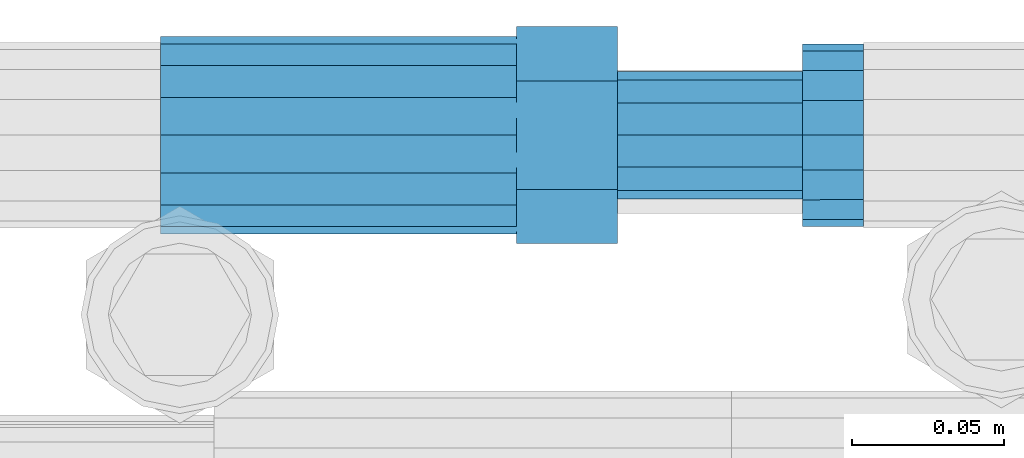
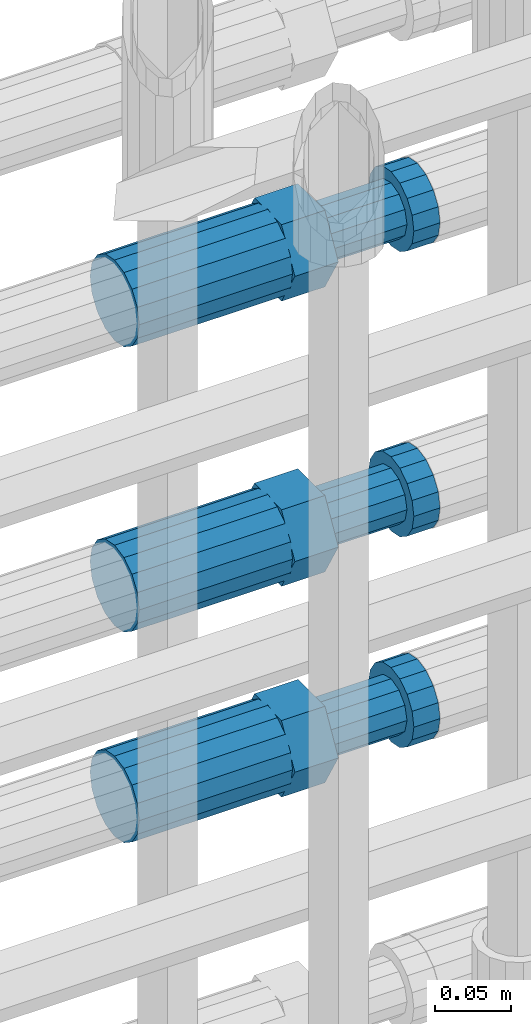
# One storey, part 81 of 119: 3 beams.
"""IFC2X3 building model written with IfcOpenShell, lengths in millimetres."""

from ifc_helpers import new_model, si_unit, frame, origin_with_axes, place, context, subcontext, project, spatial, faceted_brep, material, type_object, element, save


model = new_model("IFC2X3")

# Units and contexts
model_context = context("Model", 3, precision=1e-05, world=origin_with_axes())
body_context = subcontext(model_context, "Body", "Model", "MODEL_VIEW")
ifc_project = project(units=[si_unit("LENGTHUNIT", "METRE", prefix="MILLI"), si_unit("AREAUNIT", "SQUARE_METRE"), si_unit("VOLUMEUNIT", "CUBIC_METRE"), si_unit("MASSUNIT", "GRAM", prefix="KILO"), si_unit("TIMEUNIT", "SECOND"), si_unit("PLANEANGLEUNIT", "RADIAN"), si_unit("SOLIDANGLEUNIT", "STERADIAN"), si_unit("THERMODYNAMICTEMPERATUREUNIT", "DEGREE_CELSIUS"), si_unit("LUMINOUSINTENSITYUNIT", "LUMEN")], contexts=[model_context])

# Site, building, storey
site_placement = place(None, origin_with_axes())
site = spatial("IfcSite", under=ifc_project, at=site_placement, CompositionType="ELEMENT")
building_placement = place(site_placement, origin_with_axes())
building = spatial("IfcBuilding", under=site, at=building_placement, Name="Undefined", CompositionType="ELEMENT")
storey_placement = place(building_placement, origin_with_axes())
storey = spatial("IfcBuildingStorey", under=building, at=storey_placement, Name="Undefined", CompositionType="ELEMENT", Elevation=0.0)

# Beams
ifc_material = material(Name="STEEL/S275")
beam_type = type_object("IfcBeamType", Name="ROD65", PredefinedType="NOTDEFINED")
beam_1_placement = place(storey_placement, frame((2035848.66023304, 6206399.98994599, 20184.6894158506), z_axis=(0.0, 0.0, 1.0), x_axis=(1.0, 0.0, 0.0)))
element("IfcBeam", 1, at=beam_1_placement, inside=storey, type_object=beam_type, material=ifc_material, Name="AGB40", ObjectType="ROD65", context=body_context, shape_type="Brep", body=[
    faceted_brep([(116.999999999069, 17.8249999252148, 30.8738056446964), (116.999999998137, 22.0056957420893, 23.632628078838), (116.999999999069, 12.4372115600854, 30.0260848066173), (116.999999999069, 8.17543111252598, 30.8738056446964), (117.000000000931, -17.8250000746921, 30.8738056446964), (150.200000001118, -17.8250000723638, 30.8738056446964), (150.199999999255, 17.8249999275431, 30.8738056446964), (117.000000000931, -8.17543109622784, 30.8738056446964), (117.000000001863, -22.0056959956419, 23.6326278985034), (117.000000000931, -12.4372115437873, 30.0260848066173), (117.000000001863, -35.6500000746455, -2.18278728425503e-10), (150.200000002049, -35.6500000723172, -2.18278728425503e-10), (117.000000001863, -30.8443149488885, 8.32369080289209), (117.000000001863, -30.8443149488885, -8.32369080355784), (117.000000002794, -32.4999999918509, 0.0), (117.000000000931, -17.8250000746921, -30.873805645133), (150.200000001118, -17.8250000723638, -30.873805645133), (117.000000001863, -22.0056959961075, -23.6326278982269), (117.000000000931, -8.17543109389953, -30.873805645133), (117.000000000931, -12.4372115437873, -30.0260848066173), (116.999999999069, 17.8249999252148, -30.873805645133), (150.199999999255, 17.8249999275431, -30.873805645133), (116.999999999069, 8.17543111019768, -30.873805645133), (116.999999999069, 12.4372115600854, -30.0260848066173), (116.999999998137, 22.005695742555, -23.6326280785652), (116.999999998137, 35.6499999251682, -2.18278728425503e-10), (150.199999998324, 35.6499999277294, -2.18278728425503e-10), (116.999999998137, 30.8443150522653, -8.32369036550881), (116.999999997206, 32.5000000081491, 0.0), (116.999999998137, 30.8443150522653, 8.32369036483942), (1.86264514923096e-09, -22.9809703885112, 22.9809703885621), (1.86264514923096e-09, -30.0260848065373, 12.4372115518672), (117.000000001863, -30.0260847983882, 12.4372115518672), (117.000000001863, -22.9809703803621, 22.9809703885621), (-1.86264514923096e-09, 22.9809703885112, -22.9809703885621), (-1.86264514923096e-09, 30.0260848065373, -12.4372115518672), (116.999999998137, 30.0260848146863, -12.4372115518672), (116.999999998137, 22.9809703966603, -22.9809703885621), (1.86264514923096e-09, -30.0260848065373, -12.4372115518672), (1.86264514923096e-09, -22.9809703885112, -22.9809703885621), (117.000000001863, -22.9809703803621, -22.9809703885621), (117.000000001863, -30.0260847983882, -12.4372115518672), (9.31322574615479e-10, -12.4372115519363, 30.0260848066173), (0.0, 0.0, 32.5), (-9.31322574615479e-10, 12.4372115519363, 30.0260848066173), (-1.86264514923096e-09, 22.9809703885112, 22.9809703885621), (-1.86264514923096e-09, 30.0260848065373, 12.4372115518672), (-2.79396772384644e-09, 32.5, 0.0), (-9.31322574615479e-10, 12.4372115519363, -30.0260848066173), (0.0, 0.0, -32.5), (9.31322574615479e-10, -12.4372115519363, -30.0260848066173), (2.79396772384644e-09, -32.5, 0.0), (116.999999998137, 22.9809703966603, 22.9809703885621), (116.999999998137, 30.0260848146863, 12.4372115518672), (117.0, 8.14907252788544e-09, -32.5), (117.0, 8.14907252788544e-09, 32.5), (150.200000000186, -10.5000000959262, 18.1865334791873), (150.199999999255, -9.59262251853943e-08, 20.9999999997126), (150.199999998324, 10.4999999040738, 18.1865334791873), (150.199999997392, 18.1865333835594, 10.4999999997126), (150.199999997392, 20.9999999040738, -2.87400325760245e-10), (150.199999997392, 18.1865333835594, -10.5000000002874), (150.199999998324, 10.4999999040738, -18.1865334797621), (150.199999999255, -9.59262251853943e-08, -21.0000000002874), (150.200000000186, -10.5000000959262, -18.1865334797621), (150.200000000186, -18.1865335754119, -10.5000000002874), (150.200000001118, -21.0000000959262, -2.87400325760245e-10), (150.200000000186, -18.1865335754119, 10.4999999997126), (210.979999999516, 10.4999999082647, 18.1865334791873), (210.979999999516, -9.17352735996246e-08, 20.9999999997126), (210.979999997653, 18.1865333877504, 10.4999999997126), (210.979999997653, 20.9999999082647, -2.87400325760245e-10), (210.979999997653, 18.1865333877504, -10.5000000002874), (210.979999999516, 10.4999999082647, -18.1865334797621), (210.979999999516, -9.17352735996246e-08, -21.0000000002874), (210.979999999516, -10.5000000917353, -18.1865334797621), (210.980000000447, -18.1865335712209, -10.5000000002874), (210.980000001378, -21.0000000917353, -2.87400325760245e-10), (210.980000000447, -18.1865335712209, 10.4999999997126), (210.979999999516, -10.5000000917353, 18.1865334791873), (211.001368402503, -27.7269939335529, -11.4911163272045), (211.003082515672, -21.2238095656503, -21.2238154190527), (231.002518340945, -21.2131946226582, -21.2132004554769), (231.000804228708, -27.7163789905608, -11.4805013636287), (211.001368415542, -11.4911086384673, -27.7269970399575), (231.000804241747, -11.4804936954752, -27.7163820763781), (210.996487061493, -0.0106066407170147, -30.0106107396168), (230.995922887698, 8.30227509140968e-06, -29.999995776041), (210.98918159306, 11.4698940692469, -27.7269970332745), (230.988617419265, 11.4805090120062, -27.7163820696951), (210.980564201251, 21.2025913291145, -21.2238154067054), (230.980000027455, 21.2132062721066, -21.2132004431296), (210.971946807578, 27.7057702087332, -11.4911163110701), (230.971382633783, 27.7163851517253, -11.4805013474943), (210.964641331695, 29.9893806746695, -0.0106149565435771), (230.9640771579, 29.9999956176616, 7.03221303410828e-09), (210.959759964608, 27.7057637346443, 11.4698863966551), (230.959195790812, 27.7163786776364, 11.4805013602345), (210.958045851439, 21.2025793667417, 21.2025854885032), (230.957481677644, 21.2131943097338, 21.2132004520827), (210.959759951569, 11.4698784395587, 27.705767109408), (230.959195776843, 11.4804933823179, 27.7163820729838), (210.964641305618, -0.0106235581915826, 29.9893808090674), (230.964077131823, -8.61519947648048e-06, 29.9999957726432), (210.971946774051, -11.4911242681555, 27.7057671027251), (230.971382599324, -11.4805093251634, 27.7163820663009), (210.98056416586, -21.2238215280231, 21.2025854761559), (230.979999991134, -21.2132065852638, 21.2132004397354), (210.989181559533, -27.7270004076418, 11.4698863805206), (230.988617384806, -27.7163854646496, 11.4805013441), (210.996487035416, -30.0106108735781, -0.0106149740058754), (230.995922861621, -29.999995930586, -1.04300852399319e-08)], [[[0, 1, 2, 3]], [[4, 5, 6, 0, 3, 7]], [[8, 4, 7, 9]], [[10, 11, 5, 4, 8, 12]], [[13, 10, 12, 14]], [[15, 16, 11, 10, 13, 17]], [[18, 15, 17, 19]], [[20, 21, 16, 15, 18, 22]], [[20, 22, 23, 24]], [[25, 26, 21, 20, 24, 27]], [[25, 27, 28, 29]], [[30, 31, 32, 33]], [[34, 35, 36, 37]], [[38, 39, 40, 41]], [[31, 30, 42, 43, 44, 45, 46, 47, 35, 34, 48, 49, 50, 39, 38, 51]], [[46, 45, 52, 53]], [[28, 47, 46, 53, 29]], [[27, 36, 35, 47, 28]], [[24, 37, 36, 27]], [[23, 48, 34, 37, 24]], [[22, 54, 49, 48, 23]], [[18, 54, 22]], [[19, 50, 49, 54, 18]], [[17, 40, 39, 50, 19]], [[13, 41, 40, 17]], [[14, 51, 38, 41, 13]], [[12, 32, 31, 51, 14]], [[8, 33, 32, 12]], [[9, 42, 30, 33, 8]], [[7, 55, 43, 42, 9]], [[3, 55, 7]], [[2, 44, 43, 55, 3]], [[1, 52, 45, 44, 2]], [[29, 53, 52, 1]], [[0, 6, 26, 25, 29, 1]], [[5, 11, 16, 21, 26, 6], [56, 57, 58, 59, 60, 61, 62, 63, 64, 65, 66, 67]], [[68, 58, 57, 69]], [[70, 59, 58, 68]], [[71, 60, 59, 70]], [[72, 61, 60, 71]], [[73, 62, 61, 72]], [[74, 63, 62, 73]], [[75, 64, 63, 74]], [[76, 65, 64, 75]], [[77, 66, 65, 76]], [[78, 67, 66, 77]], [[79, 56, 67, 78]], [[69, 57, 56, 79]], [[80, 81, 82, 83]], [[81, 84, 85, 82]], [[84, 86, 87, 85]], [[86, 88, 89, 87]], [[88, 90, 91, 89]], [[90, 92, 93, 91]], [[92, 94, 95, 93]], [[94, 96, 97, 95]], [[96, 98, 99, 97]], [[98, 100, 101, 99]], [[100, 102, 103, 101]], [[102, 104, 105, 103]], [[104, 106, 107, 105]], [[106, 108, 109, 107]], [[108, 110, 111, 109]], [[82, 85, 87, 89, 91, 93, 95, 97, 99, 101, 103, 105, 107, 109, 111, 83]], [[110, 80, 83, 111]], [[108, 106, 104, 102, 100, 98, 96, 94, 92, 90, 88, 86, 84, 81, 80, 110], [78, 77, 76, 75, 74, 73, 72, 71, 70, 68, 69, 79]]]),
])
beam_2_placement = place(storey_placement, frame((2035848.66023304, 6206399.98994599, 20354.6894158506), z_axis=(0.0, 0.0, 1.0), x_axis=(1.0, 0.0, 0.0)))
element("IfcBeam", 2, at=beam_2_placement, inside=storey, type_object=beam_type, material=ifc_material, Name="AGB40", ObjectType="ROD65", context=body_context, shape_type="Brep", body=[
    faceted_brep([(116.999999999069, 17.8249999252148, 30.8738056446964), (116.999999998137, 22.0056957420893, 23.632628078838), (116.999999999069, 12.4372115600854, 30.0260848066173), (116.999999999069, 8.17543111252598, 30.8738056446964), (117.000000000931, -17.8250000746921, 30.8738056446964), (150.200000001118, -17.8250000723638, 30.8738056446964), (150.199999999255, 17.8249999275431, 30.8738056446964), (117.000000000931, -8.17543109622784, 30.8738056446964), (117.000000001863, -22.0056959956419, 23.6326278985034), (117.000000000931, -12.4372115437873, 30.0260848066173), (117.000000001863, -35.6500000746455, -2.18278728425503e-10), (150.200000002049, -35.6500000723172, -2.18278728425503e-10), (117.000000001863, -30.8443149488885, 8.32369080289209), (117.000000001863, -30.8443149488885, -8.32369080355784), (117.000000002794, -32.4999999918509, 0.0), (117.000000000931, -17.8250000746921, -30.873805645133), (150.200000001118, -17.8250000723638, -30.873805645133), (117.000000001863, -22.0056959961075, -23.6326278982269), (117.000000000931, -8.17543109389953, -30.873805645133), (117.000000000931, -12.4372115437873, -30.0260848066173), (116.999999999069, 17.8249999252148, -30.873805645133), (150.199999999255, 17.8249999275431, -30.873805645133), (116.999999999069, 8.17543111019768, -30.873805645133), (116.999999999069, 12.4372115600854, -30.0260848066173), (116.999999998137, 22.005695742555, -23.6326280785652), (116.999999998137, 35.6499999251682, -2.18278728425503e-10), (150.199999998324, 35.6499999277294, -2.18278728425503e-10), (116.999999998137, 30.8443150522653, -8.32369036550881), (116.999999997206, 32.5000000081491, 0.0), (116.999999998137, 30.8443150522653, 8.32369036483942), (1.86264514923096e-09, -22.9809703885112, 22.9809703885621), (1.86264514923096e-09, -30.0260848065373, 12.4372115518672), (117.000000001863, -30.0260847983882, 12.4372115518672), (117.000000001863, -22.9809703803621, 22.9809703885621), (-1.86264514923096e-09, 22.9809703885112, -22.9809703885621), (-1.86264514923096e-09, 30.0260848065373, -12.4372115518672), (116.999999998137, 30.0260848146863, -12.4372115518672), (116.999999998137, 22.9809703966603, -22.9809703885621), (1.86264514923096e-09, -30.0260848065373, -12.4372115518672), (1.86264514923096e-09, -22.9809703885112, -22.9809703885621), (117.000000001863, -22.9809703803621, -22.9809703885621), (117.000000001863, -30.0260847983882, -12.4372115518672), (9.31322574615479e-10, -12.4372115519363, 30.0260848066173), (0.0, 0.0, 32.5), (-9.31322574615479e-10, 12.4372115519363, 30.0260848066173), (-1.86264514923096e-09, 22.9809703885112, 22.9809703885621), (-1.86264514923096e-09, 30.0260848065373, 12.4372115518672), (-2.79396772384644e-09, 32.5, 0.0), (-9.31322574615479e-10, 12.4372115519363, -30.0260848066173), (0.0, 0.0, -32.5), (9.31322574615479e-10, -12.4372115519363, -30.0260848066173), (2.79396772384644e-09, -32.5, 0.0), (116.999999998137, 22.9809703966603, 22.9809703885621), (116.999999998137, 30.0260848146863, 12.4372115518672), (117.0, 8.14907252788544e-09, -32.5), (117.0, 8.14907252788544e-09, 32.5), (150.200000000186, -10.5000000959262, 18.1865334791873), (150.199999999255, -9.59262251853943e-08, 20.9999999997126), (150.199999998324, 10.4999999040738, 18.1865334791873), (150.199999997392, 18.1865333835594, 10.4999999997126), (150.199999997392, 20.9999999040738, -2.87400325760245e-10), (150.199999997392, 18.1865333835594, -10.5000000002874), (150.199999998324, 10.4999999040738, -18.1865334797621), (150.199999999255, -9.59262251853943e-08, -21.0000000002874), (150.200000000186, -10.5000000959262, -18.1865334797621), (150.200000000186, -18.1865335754119, -10.5000000002874), (150.200000001118, -21.0000000959262, -2.87400325760245e-10), (150.200000000186, -18.1865335754119, 10.4999999997126), (210.979999999516, 10.4999999082647, 18.1865334791873), (210.979999999516, -9.17352735996246e-08, 20.9999999997126), (210.979999997653, 18.1865333877504, 10.4999999997126), (210.979999997653, 20.9999999082647, -2.87400325760245e-10), (210.979999997653, 18.1865333877504, -10.5000000002874), (210.979999999516, 10.4999999082647, -18.1865334797621), (210.979999999516, -9.17352735996246e-08, -21.0000000002874), (210.979999999516, -10.5000000917353, -18.1865334797621), (210.980000000447, -18.1865335712209, -10.5000000002874), (210.980000001378, -21.0000000917353, -2.87400325760245e-10), (210.980000000447, -18.1865335712209, 10.4999999997126), (210.979999999516, -10.5000000917353, 18.1865334791873), (211.001368402503, -27.7269939335529, -11.4911163272045), (211.003082515672, -21.2238095656503, -21.2238154190527), (231.002518340945, -21.2131946226582, -21.2132004554769), (231.000804228708, -27.7163789905608, -11.4805013636287), (211.001368415542, -11.4911086384673, -27.7269970399575), (231.000804241747, -11.4804936954752, -27.7163820763781), (210.996487061493, -0.0106066407170147, -30.0106107396168), (230.995922887698, 8.30227509140968e-06, -29.999995776041), (210.98918159306, 11.4698940692469, -27.7269970332745), (230.988617419265, 11.4805090120062, -27.7163820696951), (210.980564201251, 21.2025913291145, -21.2238154067054), (230.980000027455, 21.2132062721066, -21.2132004431296), (210.971946807578, 27.7057702087332, -11.4911163110701), (230.971382633783, 27.7163851517253, -11.4805013474943), (210.964641331695, 29.9893806746695, -0.0106149565435771), (230.9640771579, 29.9999956176616, 7.03221303410828e-09), (210.959759964608, 27.7057637346443, 11.4698863966551), (230.959195790812, 27.7163786776364, 11.4805013602345), (210.958045851439, 21.2025793667417, 21.2025854885032), (230.957481677644, 21.2131943097338, 21.2132004520827), (210.959759951569, 11.4698784395587, 27.705767109408), (230.959195776843, 11.4804933823179, 27.7163820729838), (210.964641305618, -0.0106235581915826, 29.9893808090674), (230.964077131823, -8.61519947648048e-06, 29.9999957726432), (210.971946774051, -11.4911242681555, 27.7057671027251), (230.971382599324, -11.4805093251634, 27.7163820663009), (210.98056416586, -21.2238215280231, 21.2025854761559), (230.979999991134, -21.2132065852638, 21.2132004397354), (210.989181559533, -27.7270004076418, 11.4698863805206), (230.988617384806, -27.7163854646496, 11.4805013441), (210.996487035416, -30.0106108735781, -0.0106149740058754), (230.995922861621, -29.999995930586, -1.04300852399319e-08)], [[[0, 1, 2, 3]], [[4, 5, 6, 0, 3, 7]], [[8, 4, 7, 9]], [[10, 11, 5, 4, 8, 12]], [[13, 10, 12, 14]], [[15, 16, 11, 10, 13, 17]], [[18, 15, 17, 19]], [[20, 21, 16, 15, 18, 22]], [[20, 22, 23, 24]], [[25, 26, 21, 20, 24, 27]], [[25, 27, 28, 29]], [[30, 31, 32, 33]], [[34, 35, 36, 37]], [[38, 39, 40, 41]], [[31, 30, 42, 43, 44, 45, 46, 47, 35, 34, 48, 49, 50, 39, 38, 51]], [[46, 45, 52, 53]], [[28, 47, 46, 53, 29]], [[27, 36, 35, 47, 28]], [[24, 37, 36, 27]], [[23, 48, 34, 37, 24]], [[22, 54, 49, 48, 23]], [[18, 54, 22]], [[19, 50, 49, 54, 18]], [[17, 40, 39, 50, 19]], [[13, 41, 40, 17]], [[14, 51, 38, 41, 13]], [[12, 32, 31, 51, 14]], [[8, 33, 32, 12]], [[9, 42, 30, 33, 8]], [[7, 55, 43, 42, 9]], [[3, 55, 7]], [[2, 44, 43, 55, 3]], [[1, 52, 45, 44, 2]], [[29, 53, 52, 1]], [[0, 6, 26, 25, 29, 1]], [[5, 11, 16, 21, 26, 6], [56, 57, 58, 59, 60, 61, 62, 63, 64, 65, 66, 67]], [[68, 58, 57, 69]], [[70, 59, 58, 68]], [[71, 60, 59, 70]], [[72, 61, 60, 71]], [[73, 62, 61, 72]], [[74, 63, 62, 73]], [[75, 64, 63, 74]], [[76, 65, 64, 75]], [[77, 66, 65, 76]], [[78, 67, 66, 77]], [[79, 56, 67, 78]], [[69, 57, 56, 79]], [[80, 81, 82, 83]], [[81, 84, 85, 82]], [[84, 86, 87, 85]], [[86, 88, 89, 87]], [[88, 90, 91, 89]], [[90, 92, 93, 91]], [[92, 94, 95, 93]], [[94, 96, 97, 95]], [[96, 98, 99, 97]], [[98, 100, 101, 99]], [[100, 102, 103, 101]], [[102, 104, 105, 103]], [[104, 106, 107, 105]], [[106, 108, 109, 107]], [[108, 110, 111, 109]], [[82, 85, 87, 89, 91, 93, 95, 97, 99, 101, 103, 105, 107, 109, 111, 83]], [[110, 80, 83, 111]], [[108, 106, 104, 102, 100, 98, 96, 94, 92, 90, 88, 86, 84, 81, 80, 110], [78, 77, 76, 75, 74, 73, 72, 71, 70, 68, 69, 79]]]),
])
beam_3_placement = place(storey_placement, frame((2035848.66023304, 6206399.98994599, 20584.6894158506), z_axis=(0.0, 0.0, 1.0), x_axis=(1.0, 0.0, 0.0)))
element("IfcBeam", 3, at=beam_3_placement, inside=storey, type_object=beam_type, material=ifc_material, Name="AGB40", ObjectType="ROD65", context=body_context, shape_type="Brep", body=[
    faceted_brep([(116.999999999069, 17.8249999252148, 30.8738056446964), (116.999999998137, 22.0056957420893, 23.632628078838), (116.999999999069, 12.4372115600854, 30.0260848066173), (116.999999999069, 8.17543111252598, 30.8738056446964), (117.000000000931, -17.8250000746921, 30.8738056446964), (150.200000001118, -17.8250000723638, 30.8738056446964), (150.199999999255, 17.8249999275431, 30.8738056446964), (117.000000000931, -8.17543109622784, 30.8738056446964), (117.000000001863, -22.0056959956419, 23.6326278985034), (117.000000000931, -12.4372115437873, 30.0260848066173), (117.000000001863, -35.6500000746455, -2.18278728425503e-10), (150.200000002049, -35.6500000723172, -2.18278728425503e-10), (117.000000001863, -30.8443149488885, 8.32369080289209), (117.000000001863, -30.8443149488885, -8.32369080355784), (117.000000002794, -32.4999999918509, 0.0), (117.000000000931, -17.8250000746921, -30.873805645133), (150.200000001118, -17.8250000723638, -30.873805645133), (117.000000001863, -22.0056959961075, -23.6326278982269), (117.000000000931, -8.17543109389953, -30.873805645133), (117.000000000931, -12.4372115437873, -30.0260848066173), (116.999999999069, 17.8249999252148, -30.873805645133), (150.199999999255, 17.8249999275431, -30.873805645133), (116.999999999069, 8.17543111019768, -30.873805645133), (116.999999999069, 12.4372115600854, -30.0260848066173), (116.999999998137, 22.005695742555, -23.6326280785652), (116.999999998137, 35.6499999251682, -2.18278728425503e-10), (150.199999998324, 35.6499999277294, -2.18278728425503e-10), (116.999999998137, 30.8443150522653, -8.32369036550881), (116.999999997206, 32.5000000081491, 0.0), (116.999999998137, 30.8443150522653, 8.32369036483942), (1.86264514923096e-09, -22.9809703885112, 22.9809703885621), (1.86264514923096e-09, -30.0260848065373, 12.4372115518672), (117.000000001863, -30.0260847983882, 12.4372115518672), (117.000000001863, -22.9809703803621, 22.9809703885621), (-1.86264514923096e-09, 22.9809703885112, -22.9809703885621), (-1.86264514923096e-09, 30.0260848065373, -12.4372115518672), (116.999999998137, 30.0260848146863, -12.4372115518672), (116.999999998137, 22.9809703966603, -22.9809703885621), (1.86264514923096e-09, -30.0260848065373, -12.4372115518672), (1.86264514923096e-09, -22.9809703885112, -22.9809703885621), (117.000000001863, -22.9809703803621, -22.9809703885621), (117.000000001863, -30.0260847983882, -12.4372115518672), (9.31322574615479e-10, -12.4372115519363, 30.0260848066173), (0.0, 0.0, 32.5), (-9.31322574615479e-10, 12.4372115519363, 30.0260848066173), (-1.86264514923096e-09, 22.9809703885112, 22.9809703885621), (-1.86264514923096e-09, 30.0260848065373, 12.4372115518672), (-2.79396772384644e-09, 32.5, 0.0), (-9.31322574615479e-10, 12.4372115519363, -30.0260848066173), (0.0, 0.0, -32.5), (9.31322574615479e-10, -12.4372115519363, -30.0260848066173), (2.79396772384644e-09, -32.5, 0.0), (116.999999998137, 22.9809703966603, 22.9809703885621), (116.999999998137, 30.0260848146863, 12.4372115518672), (117.0, 8.14907252788544e-09, -32.5), (117.0, 8.14907252788544e-09, 32.5), (150.200000000186, -10.5000000959262, 18.1865334791873), (150.199999999255, -9.59262251853943e-08, 20.9999999997126), (150.199999998324, 10.4999999040738, 18.1865334791873), (150.199999997392, 18.1865333835594, 10.4999999997126), (150.199999997392, 20.9999999040738, -2.87400325760245e-10), (150.199999997392, 18.1865333835594, -10.5000000002874), (150.199999998324, 10.4999999040738, -18.1865334797621), (150.199999999255, -9.59262251853943e-08, -21.0000000002874), (150.200000000186, -10.5000000959262, -18.1865334797621), (150.200000000186, -18.1865335754119, -10.5000000002874), (150.200000001118, -21.0000000959262, -2.87400325760245e-10), (150.200000000186, -18.1865335754119, 10.4999999997126), (210.979999999516, 10.4999999082647, 18.1865334791873), (210.979999999516, -9.17352735996246e-08, 20.9999999997126), (210.979999997653, 18.1865333877504, 10.4999999997126), (210.979999997653, 20.9999999082647, -2.87400325760245e-10), (210.979999997653, 18.1865333877504, -10.5000000002874), (210.979999999516, 10.4999999082647, -18.1865334797621), (210.979999999516, -9.17352735996246e-08, -21.0000000002874), (210.979999999516, -10.5000000917353, -18.1865334797621), (210.980000000447, -18.1865335712209, -10.5000000002874), (210.980000001378, -21.0000000917353, -2.87400325760245e-10), (210.980000000447, -18.1865335712209, 10.4999999997126), (210.979999999516, -10.5000000917353, 18.1865334791873), (211.001368402503, -27.7269939335529, -11.4911163272045), (211.003082515672, -21.2238095656503, -21.2238154190527), (231.002518340945, -21.2131946226582, -21.2132004554769), (231.000804228708, -27.7163789905608, -11.4805013636287), (211.001368415542, -11.4911086384673, -27.7269970399575), (231.000804241747, -11.4804936954752, -27.7163820763781), (210.996487061493, -0.0106066407170147, -30.0106107396168), (230.995922887698, 8.30227509140968e-06, -29.999995776041), (210.98918159306, 11.4698940692469, -27.7269970332745), (230.988617419265, 11.4805090120062, -27.7163820696951), (210.980564201251, 21.2025913291145, -21.2238154067054), (230.980000027455, 21.2132062721066, -21.2132004431296), (210.971946807578, 27.7057702087332, -11.4911163110701), (230.971382633783, 27.7163851517253, -11.4805013474943), (210.964641331695, 29.9893806746695, -0.0106149565435771), (230.9640771579, 29.9999956176616, 7.03221303410828e-09), (210.959759964608, 27.7057637346443, 11.4698863966551), (230.959195790812, 27.7163786776364, 11.4805013602345), (210.958045851439, 21.2025793667417, 21.2025854885032), (230.957481677644, 21.2131943097338, 21.2132004520827), (210.959759951569, 11.4698784395587, 27.705767109408), (230.959195776843, 11.4804933823179, 27.7163820729838), (210.964641305618, -0.0106235581915826, 29.9893808090674), (230.964077131823, -8.61519947648048e-06, 29.9999957726432), (210.971946774051, -11.4911242681555, 27.7057671027251), (230.971382599324, -11.4805093251634, 27.7163820663009), (210.98056416586, -21.2238215280231, 21.2025854761559), (230.979999991134, -21.2132065852638, 21.2132004397354), (210.989181559533, -27.7270004076418, 11.4698863805206), (230.988617384806, -27.7163854646496, 11.4805013441), (210.996487035416, -30.0106108735781, -0.0106149740058754), (230.995922861621, -29.999995930586, -1.04300852399319e-08)], [[[0, 1, 2, 3]], [[4, 5, 6, 0, 3, 7]], [[8, 4, 7, 9]], [[10, 11, 5, 4, 8, 12]], [[13, 10, 12, 14]], [[15, 16, 11, 10, 13, 17]], [[18, 15, 17, 19]], [[20, 21, 16, 15, 18, 22]], [[20, 22, 23, 24]], [[25, 26, 21, 20, 24, 27]], [[25, 27, 28, 29]], [[30, 31, 32, 33]], [[34, 35, 36, 37]], [[38, 39, 40, 41]], [[31, 30, 42, 43, 44, 45, 46, 47, 35, 34, 48, 49, 50, 39, 38, 51]], [[46, 45, 52, 53]], [[28, 47, 46, 53, 29]], [[27, 36, 35, 47, 28]], [[24, 37, 36, 27]], [[23, 48, 34, 37, 24]], [[22, 54, 49, 48, 23]], [[18, 54, 22]], [[19, 50, 49, 54, 18]], [[17, 40, 39, 50, 19]], [[13, 41, 40, 17]], [[14, 51, 38, 41, 13]], [[12, 32, 31, 51, 14]], [[8, 33, 32, 12]], [[9, 42, 30, 33, 8]], [[7, 55, 43, 42, 9]], [[3, 55, 7]], [[2, 44, 43, 55, 3]], [[1, 52, 45, 44, 2]], [[29, 53, 52, 1]], [[0, 6, 26, 25, 29, 1]], [[5, 11, 16, 21, 26, 6], [56, 57, 58, 59, 60, 61, 62, 63, 64, 65, 66, 67]], [[68, 58, 57, 69]], [[70, 59, 58, 68]], [[71, 60, 59, 70]], [[72, 61, 60, 71]], [[73, 62, 61, 72]], [[74, 63, 62, 73]], [[75, 64, 63, 74]], [[76, 65, 64, 75]], [[77, 66, 65, 76]], [[78, 67, 66, 77]], [[79, 56, 67, 78]], [[69, 57, 56, 79]], [[80, 81, 82, 83]], [[81, 84, 85, 82]], [[84, 86, 87, 85]], [[86, 88, 89, 87]], [[88, 90, 91, 89]], [[90, 92, 93, 91]], [[92, 94, 95, 93]], [[94, 96, 97, 95]], [[96, 98, 99, 97]], [[98, 100, 101, 99]], [[100, 102, 103, 101]], [[102, 104, 105, 103]], [[104, 106, 107, 105]], [[106, 108, 109, 107]], [[108, 110, 111, 109]], [[82, 85, 87, 89, 91, 93, 95, 97, 99, 101, 103, 105, 107, 109, 111, 83]], [[110, 80, 83, 111]], [[108, 106, 104, 102, 100, 98, 96, 94, 92, 90, 88, 86, 84, 81, 80, 110], [78, 77, 76, 75, 74, 73, 72, 71, 70, 68, 69, 79]]]),
])

save(model, "model.ifc")
